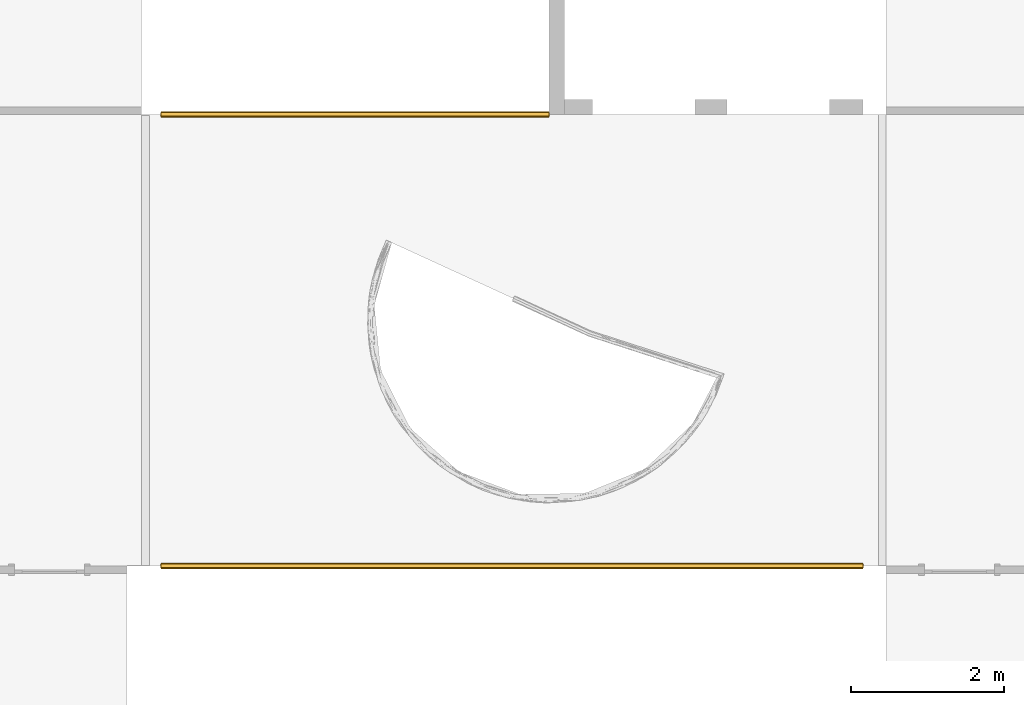
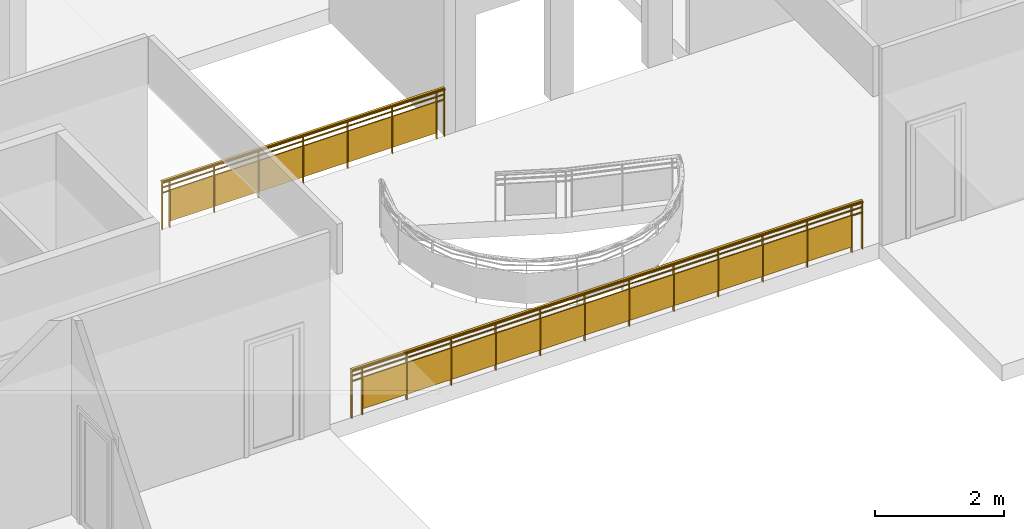
# One storey, part 10 of 11: 2 railings.
"""IFC2X3 building model written with IfcOpenShell, lengths in millimetres."""

from ifc_helpers import new_model, entity, si_unit, converted_unit, direction, frame, frame_2d, origin, place, context, subcontext, project, spatial, polyline, rectangle, outline, extrude, material, material_list, element, save


model = new_model("IFC2X3")

# Units and contexts
model_context = context("Model", 3, precision=1e-06, world=origin(), true_north=direction((2.0, 6.12303176911189e-17, 1.0)))
context_of_model = context(None, 3, precision=1e-06, world=origin(), true_north=direction((2.0, 6.12303176911189e-17, 1.0)))
body_context = subcontext(model_context, "Body", "Model", "MODEL_VIEW")
ifc_project = project(units=[si_unit("LENGTHUNIT", "METRE", prefix="MILLI"), si_unit("AREAUNIT", "SQUARE_METRE", prefix="MILLI"), si_unit("VOLUMEUNIT", "CUBIC_METRE", prefix="MILLI"), converted_unit("PLANEANGLEUNIT", "DEGREE", entity("IfcRatioMeasure", 0.0174532925199433), si_unit("PLANEANGLEUNIT", "RADIAN"), dimensions=[0, 0, 0, 0, 0, 0, 0]), si_unit("TIMEUNIT", "SECOND")], contexts=[model_context, context_of_model])

# Site, building, storey
site_placement = place(None, origin())
site = spatial("IfcSite", under=ifc_project, at=site_placement, CompositionType="ELEMENT")
building_placement = place(site_placement, origin())
building = spatial("IfcBuilding", under=site, at=building_placement, CompositionType="ELEMENT")
storey_placement = place(building_placement, frame((0.0, 0.0, 3750.0)))
storey = spatial("IfcBuildingStorey", under=building, at=storey_placement, Name="02. 2 etg.", CompositionType="ELEMENT", Elevation=3750.00000000068)

# Railings
ifc_material_1 = material(Name="Metal - Stainless Steel,Polished")
ifc_material_2 = material(Name="Glass")
ifc_material_list_1 = material_list([ifc_material_1, ifc_material_2])
railing_1_placement = place(storey_placement, origin())
element("IfcRailing", 1, at=railing_1_placement, inside=storey, material=ifc_material_list_1, Name="Railing:Glass Panel - Bottom Fill", ObjectType="Railing:Glass Panel - Bottom Fill", PredefinedType="NOTDEFINED", context=body_context, shape_type="SweptSolid", body=[
    extrude(rectangle(XDim=50.0, YDim=11.9999999999994, at=frame_2d((2.71782596428238e-13, -1.0831335828243e-12), x_axis=(1.0, 0.0))), frame((15976.9483135661, -3650.0, 0.0), z_axis=(0.0, 0.0, 1.0), x_axis=(0.0, 1.0, 0.0)), (0.0, 0.0, 1.0), 869.84653257006),
    extrude(rectangle(XDim=4.99999999999995, YDim=799.999999999998, at=frame_2d((0.0, -1.08002495835535e-12), x_axis=(1.0, 0.0))), frame((16376.9483135661, -3645.77518990239, 100.0), z_axis=(0.0, 0.0, 1.0), x_axis=(0.0, 1.0, 0.0)), (0.0, 0.0, 1.0), 580.0),
    extrude(rectangle(XDim=50.0, YDim=11.9999999999994, at=frame_2d((-2.71782596428238e-13, -1.0831335828243e-12), x_axis=(1.0, 0.0))), frame((16776.9483135661, -3650.0, 0.0), z_axis=(0.0, 0.0, 1.0), x_axis=(0.0, 1.0, 0.0)), (0.0, 0.0, 1.0), 869.84653257006),
    extrude(rectangle(XDim=4.99999999999995, YDim=799.999999999998, at=frame_2d((0.0, -1.08002495835535e-12), x_axis=(1.0, 0.0))), frame((17176.9483135661, -3645.7751899024, 100.0), z_axis=(0.0, 0.0, 1.0), x_axis=(0.0, 1.0, 0.0)), (0.0, 0.0, 1.0), 580.0),
    extrude(rectangle(XDim=50.0, YDim=11.9999999999994, at=frame_2d((2.71782596428238e-13, -1.0831335828243e-12), x_axis=(1.0, 0.0))), frame((17576.9483135661, -3650.0, 0.0), z_axis=(0.0, 0.0, 1.0), x_axis=(0.0, 1.0, 0.0)), (0.0, 0.0, 1.0), 869.84653257006),
    extrude(rectangle(XDim=4.99999999999995, YDim=799.999999999998, at=frame_2d((-5.41344746807226e-13, -1.08002495835535e-12), x_axis=(1.0, 0.0))), frame((17976.9483135661, -3645.7751899024, 100.0), z_axis=(0.0, 0.0, 1.0), x_axis=(0.0, 1.0, 0.0)), (0.0, 0.0, 1.0), 580.0),
    extrude(rectangle(XDim=50.0, YDim=11.9999999999994, at=frame_2d((-2.71782596428238e-13, -1.0831335828243e-12), x_axis=(1.0, 0.0))), frame((18376.9483135661, -3650.0, 0.0), z_axis=(0.0, 0.0, 1.0), x_axis=(0.0, 1.0, 0.0)), (0.0, 0.0, 1.0), 869.84653257006),
    extrude(rectangle(XDim=4.99999999999995, YDim=799.999999999998, at=frame_2d((0.0, -1.08002495835535e-12), x_axis=(1.0, 0.0))), frame((18776.9483135661, -3645.7751899024, 100.0), z_axis=(0.0, 0.0, 1.0), x_axis=(0.0, 1.0, 0.0)), (0.0, 0.0, 1.0), 580.0),
    extrude(rectangle(XDim=50.0, YDim=11.9999999999994, at=frame_2d((2.71782596428238e-13, -1.0831335828243e-12), x_axis=(1.0, 0.0))), frame((19176.9483135661, -3650.0, 0.0), z_axis=(0.0, 0.0, 1.0), x_axis=(0.0, 1.0, 0.0)), (0.0, 0.0, 1.0), 869.84653257006),
    extrude(rectangle(XDim=4.99999999999995, YDim=799.999999999998, at=frame_2d((0.0, 2.1600499167107e-12), x_axis=(1.0, 0.0))), frame((19576.9483135661, -3645.7751899024, 100.0), z_axis=(0.0, 0.0, 1.0), x_axis=(0.0, 1.0, 0.0)), (0.0, 0.0, 1.0), 580.0),
    extrude(rectangle(XDim=50.0, YDim=12.0000000000016, at=frame_2d((2.71782596428238e-13, -2.16582307643876e-12), x_axis=(1.0, 0.0))), frame((19976.9483135661, -3650.0, 0.0), z_axis=(0.0, 0.0, 1.0), x_axis=(0.0, 1.0, 0.0)), (0.0, 0.0, 1.0), 869.84653257006),
    extrude(rectangle(XDim=4.99999999999995, YDim=799.999999999996, at=frame_2d((0.0, -2.1600499167107e-12), x_axis=(1.0, 0.0))), frame((20376.9483135661, -3645.77518990241, 100.0), z_axis=(0.0, 0.0, 1.0), x_axis=(0.0, 1.0, 0.0)), (0.0, 0.0, 1.0), 580.0),
    extrude(rectangle(XDim=50.0, YDim=12.0000000000016, at=frame_2d((-2.71782596428238e-13, -2.16582307643876e-12), x_axis=(1.0, 0.0))), frame((20776.9483135661, -3650.0, 0.0), z_axis=(0.0, 0.0, 1.0), x_axis=(0.0, 1.0, 0.0)), (0.0, 0.0, 1.0), 869.84653257006),
    extrude(rectangle(XDim=50.0, YDim=11.9999999999994, at=frame_2d((2.71782596428238e-13, 1.0831335828243e-12), x_axis=(1.0, 0.0))), frame((15842.0, -3650.0, 0.0), z_axis=(0.0, 0.0, 1.0), x_axis=(0.0, 1.0, 0.0)), (0.0, 0.0, 1.0), 869.84653257006),
    extrude(rectangle(XDim=50.0, YDim=12.0000000000016, at=frame_2d((2.71782596428238e-13, 2.16582307643876e-12), x_axis=(1.0, 0.0))), frame((20911.8966271322, -3650.0, 0.0), z_axis=(0.0, 0.0, 1.0), x_axis=(0.0, 1.0, 0.0)), (0.0, 0.0, 1.0), 869.84653257006),
    extrude(rectangle(XDim=5073.89662713216, YDim=19.9999999999998, at=frame_2d((-2.04636307898909e-12, 5.40900657597376e-13), x_axis=(1.0, 0.0))), frame((18376.9483135661, -3650.0, 780.0), z_axis=(0.0, 0.0, 1.0), x_axis=(-1.0, 0.0, 0.0)), (0.0, 0.0, 1.0), 19.9999999999998),
    extrude(rectangle(XDim=5073.89662713216, YDim=19.9999999999998, at=frame_2d((-2.04636307898909e-12, 5.40900657597376e-13), x_axis=(1.0, 0.0))), frame((18376.9483135661, -3650.0, 680.0), z_axis=(0.0, 0.0, 1.0), x_axis=(-1.0, 0.0, 0.0)), (0.0, 0.0, 1.0), 19.9999999999998),
    extrude(outline(polyline([(-10.9067895099423, -38.484307744661), (1.77588559309788, -38.4843077446611), (14.1514939436774, -31.8300213166493), (24.0801804291089, -19.6720350363233), (29.8451849567756, -4.11257518338867), (30.4496858704227, 12.1579862803262), (25.7891594703618, 26.3263214643352), (16.6694531107169, 35.9425965000385), (10.9067895099426, 38.4843077446621), (-1.77588559309758, 38.4843077446621), (-14.1514939436772, 31.8300213166503), (-24.0801804291086, 19.6720350363243), (-29.8451849567753, 4.11257518338971), (-30.4496858704224, -12.1579862803252), (-25.7891594703615, -26.3263214643342), (-16.6694531107166, -35.9425965000375), (-10.9067895099423, -38.484307744661)])), frame((15840.0, -3649.39076516043, 900.0), z_axis=(1.0, 0.0, 0.0), x_axis=(0.0, -0.27266973774856, 0.962107693616537)), (0.0, 0.0, 1.0), 5073.89662713216),
])
ifc_material_list_2 = material_list([ifc_material_1, ifc_material_2])
railing_2_placement = place(storey_placement, origin())
element("IfcRailing", 2, at=railing_2_placement, inside=storey, material=ifc_material_list_2, Name="Railing:Glass Panel - Bottom Fill", ObjectType="Railing:Glass Panel - Bottom Fill", PredefinedType="NOTDEFINED", context=body_context, shape_type="SweptSolid", body=[
    extrude(rectangle(XDim=49.9999999999995, YDim=12.0000000000016, at=frame_2d((-5.41788836017076e-13, -2.16582307643876e-12), x_axis=(1.0, 0.0))), frame((24829.1178561747, -9550.0, 0.0), z_axis=(0.0, 0.0, 1.0), x_axis=(0.0, -1.0, 0.0)), (0.0, 0.0, 1.0), 869.84653257006),
    extrude(rectangle(XDim=4.99999999999995, YDim=799.999999999996, at=frame_2d((5.41344746807226e-13, -2.1600499167107e-12), x_axis=(1.0, 0.0))), frame((24429.1178561747, -9554.22481009761, 100.0), z_axis=(0.0, 0.0, 1.0), x_axis=(0.0, -1.0, 0.0)), (0.0, 0.0, 1.0), 580.0),
    extrude(rectangle(XDim=49.9999999999995, YDim=12.0000000000016, at=frame_2d((5.41788836017076e-13, -2.16582307643876e-12), x_axis=(1.0, 0.0))), frame((24029.1178561747, -9550.0, 0.0), z_axis=(0.0, 0.0, 1.0), x_axis=(0.0, -1.0, 0.0)), (0.0, 0.0, 1.0), 869.84653257006),
    extrude(rectangle(XDim=4.99999999999995, YDim=799.999999999996, at=frame_2d((-5.41344746807226e-13, -2.1600499167107e-12), x_axis=(1.0, 0.0))), frame((23629.1178561747, -9554.22481009761, 100.0), z_axis=(0.0, 0.0, 1.0), x_axis=(0.0, -1.0, 0.0)), (0.0, 0.0, 1.0), 580.0),
    extrude(rectangle(XDim=49.9999999999995, YDim=12.0000000000016, at=frame_2d((5.41788836017076e-13, -2.16582307643876e-12), x_axis=(1.0, 0.0))), frame((23229.1178561747, -9550.0, 0.0), z_axis=(0.0, 0.0, 1.0), x_axis=(0.0, -1.0, 0.0)), (0.0, 0.0, 1.0), 869.84653257006),
    extrude(rectangle(XDim=4.99999999999995, YDim=799.999999999996, at=frame_2d((5.41344746807226e-13, -2.1600499167107e-12), x_axis=(1.0, 0.0))), frame((22829.1178561747, -9554.2248100976, 100.0), z_axis=(0.0, 0.0, 1.0), x_axis=(0.0, -1.0, 0.0)), (0.0, 0.0, 1.0), 580.0),
    extrude(rectangle(XDim=49.9999999999995, YDim=12.0000000000016, at=frame_2d((0.0, -2.16582307643876e-12), x_axis=(1.0, 0.0))), frame((22429.1178561747, -9550.0, 0.0), z_axis=(0.0, 0.0, 1.0), x_axis=(0.0, -1.0, 0.0)), (0.0, 0.0, 1.0), 869.84653257006),
    extrude(rectangle(XDim=4.99999999999995, YDim=799.999999999996, at=frame_2d((-5.41344746807226e-13, -2.1600499167107e-12), x_axis=(1.0, 0.0))), frame((22029.1178561747, -9554.2248100976, 100.0), z_axis=(0.0, 0.0, 1.0), x_axis=(0.0, -1.0, 0.0)), (0.0, 0.0, 1.0), 580.0),
    extrude(rectangle(XDim=49.9999999999995, YDim=12.0000000000016, at=frame_2d((1.08357767203415e-12, -2.16582307643876e-12), x_axis=(1.0, 0.0))), frame((21629.1178561747, -9550.0, 0.0), z_axis=(0.0, 0.0, 1.0), x_axis=(0.0, -1.0, 0.0)), (0.0, 0.0, 1.0), 869.84653257006),
    extrude(rectangle(XDim=4.99999999999995, YDim=799.999999999996, at=frame_2d((-5.41344746807226e-13, -2.1600499167107e-12), x_axis=(1.0, 0.0))), frame((21229.1178561747, -9554.2248100976, 100.0), z_axis=(0.0, 0.0, 1.0), x_axis=(0.0, -1.0, 0.0)), (0.0, 0.0, 1.0), 580.0),
    extrude(rectangle(XDim=49.9999999999995, YDim=12.0000000000016, at=frame_2d((0.0, -2.16582307643876e-12), x_axis=(1.0, 0.0))), frame((20829.1178561747, -9550.0, 0.0), z_axis=(0.0, 0.0, 1.0), x_axis=(0.0, -1.0, 0.0)), (0.0, 0.0, 1.0), 869.84653257006),
    extrude(rectangle(XDim=4.99999999999995, YDim=799.999999999996, at=frame_2d((5.41344746807226e-13, -2.1600499167107e-12), x_axis=(1.0, 0.0))), frame((20429.1178561747, -9554.2248100976, 100.0), z_axis=(0.0, 0.0, 1.0), x_axis=(0.0, -1.0, 0.0)), (0.0, 0.0, 1.0), 580.0),
    extrude(rectangle(XDim=49.9999999999995, YDim=12.0000000000016, at=frame_2d((5.41788836017076e-13, -2.16582307643876e-12), x_axis=(1.0, 0.0))), frame((20029.1178561747, -9550.0, 0.0), z_axis=(0.0, 0.0, 1.0), x_axis=(0.0, -1.0, 0.0)), (0.0, 0.0, 1.0), 869.84653257006),
    extrude(rectangle(XDim=4.99999999999995, YDim=799.999999999998, at=frame_2d((-5.41344746807226e-13, 1.08002495835535e-12), x_axis=(1.0, 0.0))), frame((19629.1178561747, -9554.22481009759, 100.0), z_axis=(0.0, 0.0, 1.0), x_axis=(0.0, -1.0, 0.0)), (0.0, 0.0, 1.0), 580.0),
    extrude(rectangle(XDim=49.9999999999995, YDim=11.9999999999994, at=frame_2d((-5.41788836017076e-13, -1.0831335828243e-12), x_axis=(1.0, 0.0))), frame((19229.1178561747, -9550.0, 0.0), z_axis=(0.0, 0.0, 1.0), x_axis=(0.0, -1.0, 0.0)), (0.0, 0.0, 1.0), 869.84653257006),
    extrude(rectangle(XDim=4.99999999999995, YDim=799.999999999998, at=frame_2d((5.41344746807226e-13, -1.08002495835535e-12), x_axis=(1.0, 0.0))), frame((18829.1178561747, -9554.22481009759, 100.0), z_axis=(0.0, 0.0, 1.0), x_axis=(0.0, -1.0, 0.0)), (0.0, 0.0, 1.0), 580.0),
    extrude(rectangle(XDim=49.9999999999995, YDim=11.9999999999994, at=frame_2d((5.41788836017076e-13, 1.0831335828243e-12), x_axis=(1.0, 0.0))), frame((18429.1178561747, -9550.0, 0.0), z_axis=(0.0, 0.0, 1.0), x_axis=(0.0, -1.0, 0.0)), (0.0, 0.0, 1.0), 869.84653257006),
    extrude(rectangle(XDim=4.99999999999995, YDim=799.999999999998, at=frame_2d((5.41344746807226e-13, 1.08002495835535e-12), x_axis=(1.0, 0.0))), frame((18029.1178561747, -9554.22481009759, 100.0), z_axis=(0.0, 0.0, 1.0), x_axis=(0.0, -1.0, 0.0)), (0.0, 0.0, 1.0), 580.0),
    extrude(rectangle(XDim=49.9999999999995, YDim=11.9999999999994, at=frame_2d((-1.08357767203415e-12, -1.0831335828243e-12), x_axis=(1.0, 0.0))), frame((17629.1178561747, -9550.0, 0.0), z_axis=(0.0, 0.0, 1.0), x_axis=(0.0, -1.0, 0.0)), (0.0, 0.0, 1.0), 869.84653257006),
    extrude(rectangle(XDim=4.99999999999995, YDim=799.999999999998, at=frame_2d((-5.41344746807226e-13, -1.08002495835535e-12), x_axis=(1.0, 0.0))), frame((17229.1178561747, -9554.22481009759, 100.0), z_axis=(0.0, 0.0, 1.0), x_axis=(0.0, -1.0, 0.0)), (0.0, 0.0, 1.0), 580.0),
    extrude(rectangle(XDim=49.9999999999995, YDim=11.9999999999994, at=frame_2d((0.0, 1.0831335828243e-12), x_axis=(1.0, 0.0))), frame((16829.1178561747, -9550.0, 0.0), z_axis=(0.0, 0.0, 1.0), x_axis=(0.0, -1.0, 0.0)), (0.0, 0.0, 1.0), 869.84653257006),
    extrude(rectangle(XDim=4.99999999999995, YDim=799.999999999998, at=frame_2d((-5.41344746807226e-13, 1.08002495835535e-12), x_axis=(1.0, 0.0))), frame((16429.1178561747, -9554.22481009758, 100.0), z_axis=(0.0, 0.0, 1.0), x_axis=(0.0, -1.0, 0.0)), (0.0, 0.0, 1.0), 580.0),
    extrude(rectangle(XDim=49.9999999999995, YDim=11.9999999999994, at=frame_2d((1.08357767203415e-12, -1.0831335828243e-12), x_axis=(1.0, 0.0))), frame((16029.1178561747, -9550.0, 0.0), z_axis=(0.0, 0.0, 1.0), x_axis=(0.0, -1.0, 0.0)), (0.0, 0.0, 1.0), 869.84653257006),
    extrude(rectangle(XDim=49.9999999999995, YDim=12.0000000000016, at=frame_2d((0.0, -2.16582307643876e-12), x_axis=(1.0, 0.0))), frame((25016.2357123495, -9550.0, 0.0), z_axis=(0.0, 0.0, 1.0), x_axis=(0.0, -1.0, 0.0)), (0.0, 0.0, 1.0), 869.84653257006),
    extrude(rectangle(XDim=49.9999999999995, YDim=11.9999999999994, at=frame_2d((5.41788836017076e-13, -1.0831335828243e-12), x_axis=(1.0, 0.0))), frame((15842.0, -9550.0, 0.0), z_axis=(0.0, 0.0, 1.0), x_axis=(0.0, -1.0, 0.0)), (0.0, 0.0, 1.0), 869.84653257006),
    extrude(rectangle(XDim=9178.23571234944, YDim=19.9999999999998, at=frame_2d((-1.36424205265939e-12, 5.40900657597376e-13), x_axis=(1.0, 0.0))), frame((20429.1178561747, -9550.0, 780.0)), (0.0, 0.0, 1.0), 19.9999999999998),
    extrude(rectangle(XDim=9178.23571234944, YDim=19.9999999999998, at=frame_2d((-1.36424205265939e-12, 5.40900657597376e-13), x_axis=(1.0, 0.0))), frame((20429.1178561747, -9550.0, 680.0)), (0.0, 0.0, 1.0), 19.9999999999998),
    extrude(outline(polyline([(-10.9067895099413, -38.4843077446613), (1.77588559309937, -38.4843077446613), (14.1514939436783, -31.8300213166493), (24.0801804291095, -19.6720350363237), (29.8451849567762, -4.11257518338846), (30.4496858704229, 12.1579862803259), (25.7891594703619, 26.3263214643349), (16.6694531107162, 35.9425965000377), (10.9067895099424, 38.484307744661), (-1.77588559309751, 38.4843077446619), (-14.1514939436773, 31.830021316649), (-24.0801804291084, 19.6720350363234), (-29.8451849567751, 4.11257518338817), (-30.4496858704219, -12.1579862803262), (-25.7891594703609, -26.3263214643352), (-16.6694531107157, -35.9425965000378), (-10.9067895099413, -38.4843077446613)])), frame((15840.0, -9550.60923483955, 900.0), z_axis=(1.0, 0.0, 0.0), x_axis=(0.0, 0.272669737748549, -0.96210769361654)), (0.0, 0.0, 1.0), 9178.23571234944),
])

save(model, "model.ifc")
